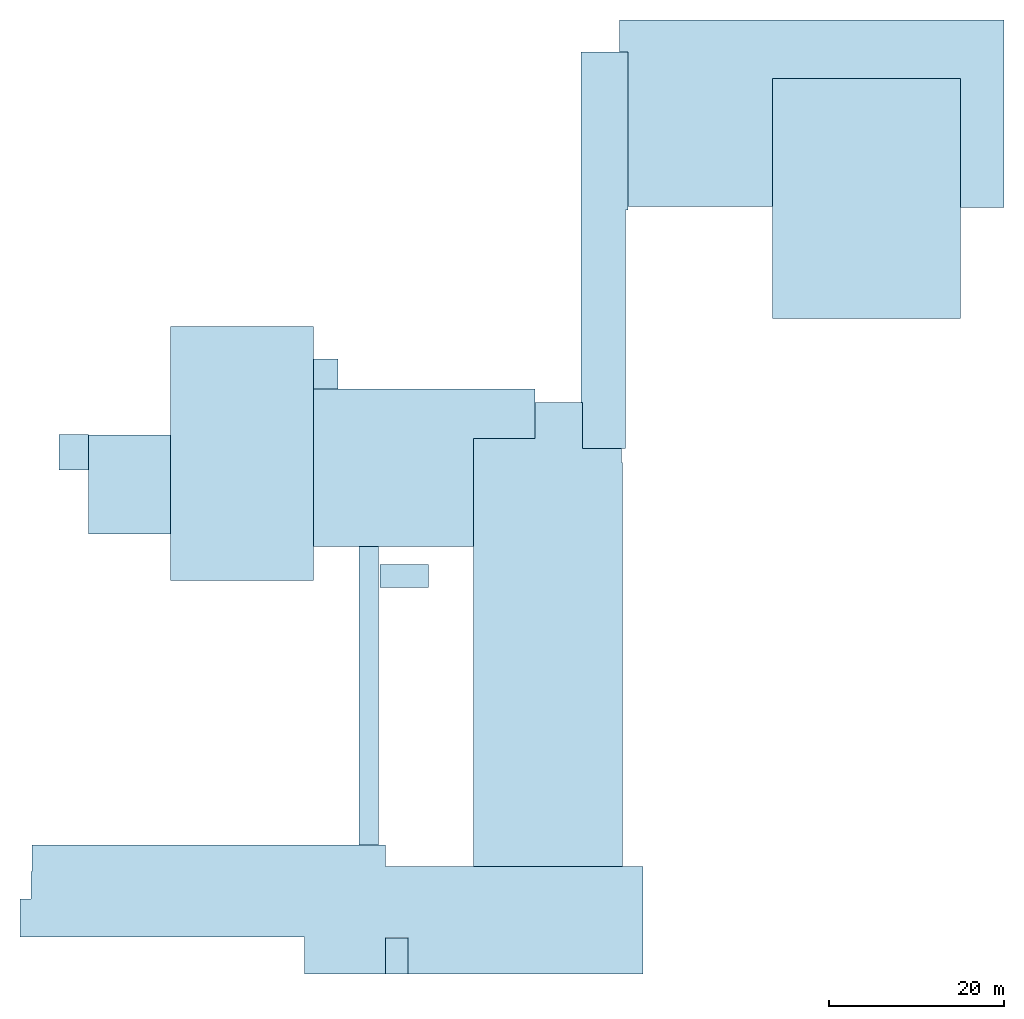
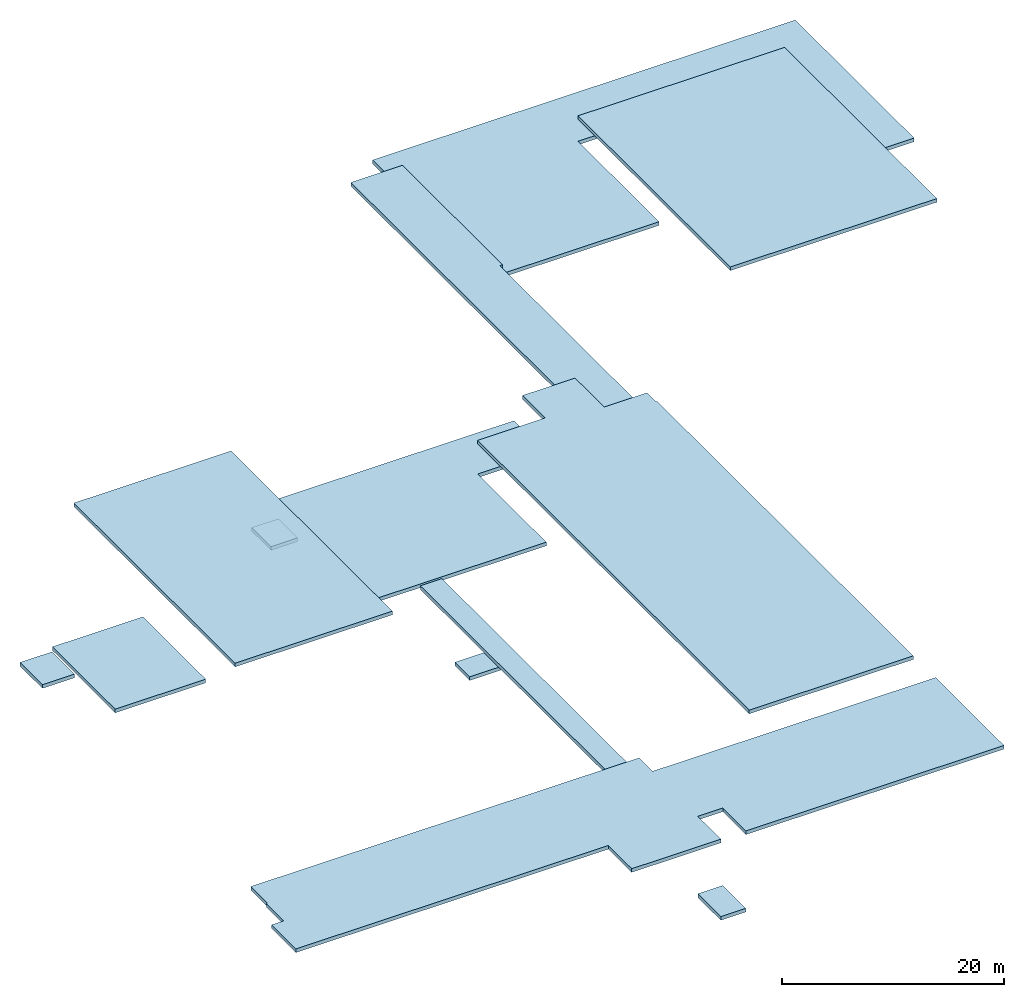
# One storey: 13 slabs.
"""IFC2X3 building model written with IfcOpenShell, lengths in metres."""

from ifc_helpers import new_model, entity, si_unit, converted_unit, derived_unit, frame, origin_with_axes, place, context, project, spatial, polyline, outline, extrude, type_object, element, save


model = new_model("IFC2X3")

# Units and contexts
context_of_model_1 = context(None, 3, world=origin_with_axes())
context_of_model_2 = context(None, 3, world=origin_with_axes())
context_of_model_3 = context(None, 2, world=origin_with_axes())
context_of_model_4 = context(None, 3, world=origin_with_axes())
ifc_project = project(units=[si_unit("LENGTHUNIT", "METRE"), si_unit("AREAUNIT", "SQUARE_METRE"), si_unit("ELECTRICCURRENTUNIT", "AMPERE"), si_unit("ELECTRICVOLTAGEUNIT", "VOLT"), si_unit("ELECTRICRESISTANCEUNIT", "OHM"), si_unit("POWERUNIT", "WATT"), si_unit("MASSUNIT", "GRAM"), si_unit("SOLIDANGLEUNIT", "STERADIAN"), si_unit("THERMODYNAMICTEMPERATUREUNIT", "KELVIN"), si_unit("PRESSUREUNIT", "PASCAL"), si_unit("LUMINOUSFLUXUNIT", "LUMEN"), si_unit("ILLUMINANCEUNIT", "LUX"), si_unit("FREQUENCYUNIT", "HERTZ"), si_unit("VOLUMEUNIT", "CUBIC_METRE"), si_unit("TIMEUNIT", "SECOND"), derived_unit("VOLUMETRICFLOWRATEUNIT", [(si_unit("TIMEUNIT", "SECOND"), -1), (si_unit("VOLUMEUNIT", "CUBIC_METRE"), 1)]), derived_unit("THERMALTRANSMITTANCEUNIT", [(si_unit("AREAUNIT", "SQUARE_METRE"), -1), (si_unit("THERMODYNAMICTEMPERATUREUNIT", "KELVIN"), -1), (si_unit("POWERUNIT", "WATT"), 1)]), converted_unit("PLANEANGLEUNIT", "DEGREE", entity("IfcPlaneAngleMeasure", 57.29577951308232), si_unit("PLANEANGLEUNIT", "RADIAN"), dimensions=[0, 0, 0, 0, 0, 0, 0])], contexts=[context_of_model_1, context_of_model_2, context_of_model_3, context_of_model_4])

# Site, building, storey
site = spatial("IfcSite", under=ifc_project, CompositionType="ELEMENT")
building_placement = place(None, origin_with_axes())
building = spatial("IfcBuilding", under=site, at=building_placement, Name="200", CompositionType="ELEMENT")
storey_placement = place(building_placement, frame((0.0, 0.0, 19.60000038146973), z_axis=(0.0, 0.0, 1.0), x_axis=(1.0, 0.0, 0.0)))
storey = spatial("IfcBuildingStorey", under=building, at=storey_placement, Name="Takplan", CompositionType="ELEMENT", Elevation=19.60000038146973)

# Slabs
slab_type_1 = type_object("IfcSlabType", PredefinedType="ROOF")
slab_1_placement = place(storey_placement, frame((-19.70732498168945, 2.602571487426758, -4.199999809265137), z_axis=(0.0, 0.0, 1.0), x_axis=(1.0, 0.0, 0.0)))
element("IfcSlab", 1, at=slab_1_placement, inside=storey, type_object=slab_type_1, PredefinedType="ROOF", context=context_of_model_1, shape_type="SweptSolid", body=[
    extrude(outline(polyline([(0.0, 0.0), (2.249855041503906, 0.0), (2.249855041503906, 34.0795841217041), (0.0, 34.0795841217041), (0.0, 0.0)])), origin_with_axes(), (0.0, 0.0, 1.0), 0.4),
])
slab_type_2 = type_object("IfcSlabType", PredefinedType="ROOF")
slab_2_placement = place(storey_placement, frame((-6.618987560272217, 0.180879220366478, -0.300000011920929), z_axis=(0.0, 0.0, 1.0), x_axis=(1.0, 0.0, 0.0)))
element("IfcSlab", 2, at=slab_2_placement, inside=storey, type_object=slab_type_2, PredefinedType="ROOF", context=context_of_model_1, shape_type="SweptSolid", body=[
    extrude(outline(polyline([(0.0, 0.0), (17.03420686721802, 0.0), (17.03420686721802, 46.06800688803196), (16.9130072593689, 46.06800688803196), (16.9130072593689, 47.68636550009251), (12.46376085281372, 47.68636550009251), (12.46376085281372, 52.92078246176243), (7.00734555721283, 52.92078246176243), (7.00734555721283, 48.85259474813938), (4.76837158203125e-07, 48.85259474813938), (0.0, 0.0)])), origin_with_axes(), (0.0, 0.0, 1.0), 0.4),
])
slab_type_3 = type_object("IfcSlabType", PredefinedType="ROOF")
slab_3_placement = place(storey_placement, frame((5.844773292541504, 47.86724472045898, -3.0), z_axis=(0.0, 0.0, 1.0), x_axis=(1.0, 0.0, 0.0)))
element("IfcSlab", 3, at=slab_3_placement, inside=storey, type_object=slab_type_3, PredefinedType="ROOF", context=context_of_model_1, shape_type="SweptSolid", body=[
    extrude(outline(polyline([(0.0, 0.0), (4.890226364135742, 0.0), (4.890225410461426, 27.2318000793457), (5.167417526245117, 27.2318000793457), (5.167416572570801, 45.22024154663086), (-0.1995806694030762, 45.22024154663086), (-0.199582576751709, 5.234416961669922), (0.0, 5.234416961669922), (0.0, 0.0)])), origin_with_axes(), (0.0, 0.0, 1.0), 0.4),
])
slab_type_4 = type_object("IfcSlabType", PredefinedType="ROOF")
slab_4_placement = place(storey_placement, frame((-50.56872940063477, 38.09762954711914, -7.800000190734863), z_axis=(0.0, 0.0, 1.0), x_axis=(1.0, 0.0, 0.0)))
element("IfcSlab", 4, at=slab_4_placement, inside=storey, type_object=slab_type_4, PredefinedType="ROOF", context=context_of_model_1, shape_type="SweptSolid", body=[
    extrude(outline(polyline([(0.0, 0.0), (9.399852752685547, 0.0), (9.399852752685547, 11.28781509399414), (0.0, 11.28781509399414), (0.0, 0.0)])), origin_with_axes(), (0.0, 0.0, 1.0), 0.4),
])
slab_type_5 = type_object("IfcSlabType", PredefinedType="ROOF")
slab_5_placement = place(storey_placement, frame((-24.84822082519531, 36.68202590942383, -4.0), z_axis=(0.0, 0.0, 1.0), x_axis=(1.0, 0.0, 0.0)))
element("IfcSlab", 5, at=slab_5_placement, inside=storey, type_object=slab_type_5, PredefinedType="ROOF", context=context_of_model_1, shape_type="SweptSolid", body=[
    extrude(outline(polyline([(0.0, 0.0), (18.2292332649231, 0.0), (18.2292332649231, 12.35144805908203), (25.23657897114754, 12.35144805908203), (25.23657897114754, 16.41963577270508), (25.2365787923336, 17.95162582397461), (0.0, 17.95162582397461), (0.0, 0.0)])), origin_with_axes(), (0.0, 0.0, 1.0), 0.4),
])
slab_type_6 = type_object("IfcSlabType", PredefinedType="ROOF")
slab_6_placement = place(storey_placement, frame((11.01219081878662, 75.49626159667969, -4.300000190734863), z_axis=(0.0, 0.0, 1.0), x_axis=(1.0, 0.0, 0.0)))
element("IfcSlab", 6, at=slab_6_placement, inside=storey, type_object=slab_type_6, PredefinedType="ROOF", context=context_of_model_1, shape_type="SweptSolid", body=[
    extrude(outline(polyline([(0.0, 0.0), (16.48825359344482, 0.0), (16.48825359344482, 14.56979370117188), (37.93536853790283, 14.56979370117188), (37.93536853790283, -0.11029052734375), (42.91530323028565, -0.11029052734375), (42.91530323028565, 21.26992797851563), (-0.9882907867431641, 21.26992797851563), (-0.9882907867431641, 17.59122467041016), (-9.5367431640625e-07, 17.59122467041016), (0.0, 0.0)])), origin_with_axes(), (0.0, 0.0, 1.0), 0.4),
])
slab_type_7 = type_object("IfcSlabType", PredefinedType="ROOF")
slab_7_placement = place(storey_placement, frame((27.50044441223145, 62.69001007080078, -1.5), z_axis=(0.0, 0.0, 1.0), x_axis=(1.0, 0.0, 0.0)))
element("IfcSlab", 7, at=slab_7_placement, inside=storey, type_object=slab_type_7, PredefinedType="ROOF", context=context_of_model_1, shape_type="SweptSolid", body=[
    extrude(outline(polyline([(0.0, 0.0), (21.44711494445801, 0.0), (21.44711494445801, 27.37604522705078), (0.0, 27.37604522705078), (0.0, 0.0)])), origin_with_axes(), (0.0, 0.0, 1.0), 0.4),
])
slab_type_8 = type_object("IfcSlabType", PredefinedType="ROOF")
slab_8_placement = place(storey_placement, frame((-16.66676139831543, -12.11274719238281, -12.0), z_axis=(0.0, 0.0, 1.0), x_axis=(1.0, 0.0, 0.0)))
element("IfcSlab", 8, at=slab_8_placement, inside=storey, type_object=slab_type_8, PredefinedType="ROOF", context=context_of_model_1, shape_type="SweptSolid", body=[
    extrude(outline(polyline([(0.0, 0.0), (2.598212242126465, 0.0), (2.598212242126465, 4.141592502593994), (0.0, 4.141592502593994), (0.0, 0.0)])), origin_with_axes(), (0.0, 0.0, 1.0), 0.4),
])
slab_type_9 = type_object("IfcSlabType", PredefinedType="ROOF")
slab_9_placement = place(storey_placement, frame((-24.84660339355469, 54.63365173339844, -9.0), z_axis=(0.0, 0.0, 1.0), x_axis=(1.0, 0.0, 0.0)))
element("IfcSlab", 9, at=slab_9_placement, inside=storey, type_object=slab_type_9, PredefinedType="ROOF", context=context_of_model_1, shape_type="SweptSolid", body=[
    extrude(outline(polyline([(0.0, 0.0), (2.768356323242188, 0.0), (2.768356323242188, 3.469654083251953), (0.0, 3.469654083251953), (0.0, 0.0)])), origin_with_axes(), (0.0, 0.0, 1.0), 0.4),
])
slab_type_10 = type_object("IfcSlabType", PredefinedType="ROOF")
slab_10_placement = place(storey_placement, frame((-53.89299774169922, 45.43281936645508, -8.399999618530273), z_axis=(0.0, 0.0, 1.0), x_axis=(1.0, 0.0, 0.0)))
element("IfcSlab", 10, at=slab_10_placement, inside=storey, type_object=slab_type_10, PredefinedType="ROOF", context=context_of_model_1, shape_type="SweptSolid", body=[
    extrude(outline(polyline([(0.0, 0.0), (3.324268341064453, 0.0), (3.324268341064453, 4.031265258789063), (0.0, 4.031265258789063), (0.0, 0.0)])), origin_with_axes(), (0.0, 0.0, 1.0), 0.4),
])
slab_type_11 = type_object("IfcSlabType", PredefinedType="ROOF")
slab_11_placement = place(storey_placement, frame((-41.16887664794922, 32.80936431884766, -2.839999914169312), z_axis=(0.0, 0.0, 1.0), x_axis=(1.0, 0.0, 0.0)))
element("IfcSlab", 11, at=slab_11_placement, inside=storey, type_object=slab_type_11, PredefinedType="ROOF", context=context_of_model_1, shape_type="SweptSolid", body=[
    extrude(outline(polyline([(0.0, 0.0), (16.32065582275391, 0.0), (16.32065582275391, 29.00522994995117), (0.0, 29.00522994995117), (0.0, 0.0)])), origin_with_axes(), (0.0, 0.0, 1.0), 0.4),
])
slab_type_12 = type_object("IfcSlabType", PredefinedType="ROOF")
slab_12_placement = place(storey_placement, frame((-17.28859710693359, 31.98393058776856, -12.19999980926514), z_axis=(0.0, 0.0, 1.0), x_axis=(1.0, 0.0, 0.0)))
element("IfcSlab", 12, at=slab_12_placement, inside=storey, type_object=slab_type_12, PredefinedType="ROOF", context=context_of_model_1, shape_type="SweptSolid", body=[
    extrude(outline(polyline([(0.0, 0.0), (5.550000190734863, 0.0), (5.550000190734863, 2.649999618530273), (0.0, 2.649999618530273), (0.0, 0.0)])), origin_with_axes(), (0.0, 0.0, 1.0), 0.4),
])
slab_type_13 = type_object("IfcSlabType", PredefinedType="ROOF")
slab_13_placement = place(storey_placement, frame((-16.65818405151367, 2.602571487426758, -3.5), z_axis=(0.0, 0.0, 1.0), x_axis=(-1.0, 0.0, 0.0)))
element("IfcSlab", 13, at=slab_13_placement, inside=storey, type_object=slab_type_13, PredefinedType="ROOF", context=context_of_model_1, shape_type="SweptSolid", body=[
    extrude(outline(polyline([(0.0, 0.0), (40.31928253173828, 0.0), (40.31928253173828, 3.003242492675781), (40.45016098022461, 3.003242492675781), (40.45016098022461, 6.138206720352173), (41.71035003662109, 6.138206720352173), (41.71035003662109, 10.50583744049072), (9.260381698608398, 10.50583744049072), (9.260381698608398, 14.71531867980957), (0.008577346801757812, 14.71531867980957), (0.008577346801757812, 10.5650954246521), (-2.589634895324707, 10.5650954246521), (-2.589634895324707, 14.71876049041748), (-29.39442157745361, 14.71876049041748), (-29.39442157745361, 2.421125710010529), (0.0, 2.421125710010529), (0.0, 0.0)])), origin_with_axes(), (0.0, 0.0, 1.0), 0.4),
])

save(model, "model.ifc")
